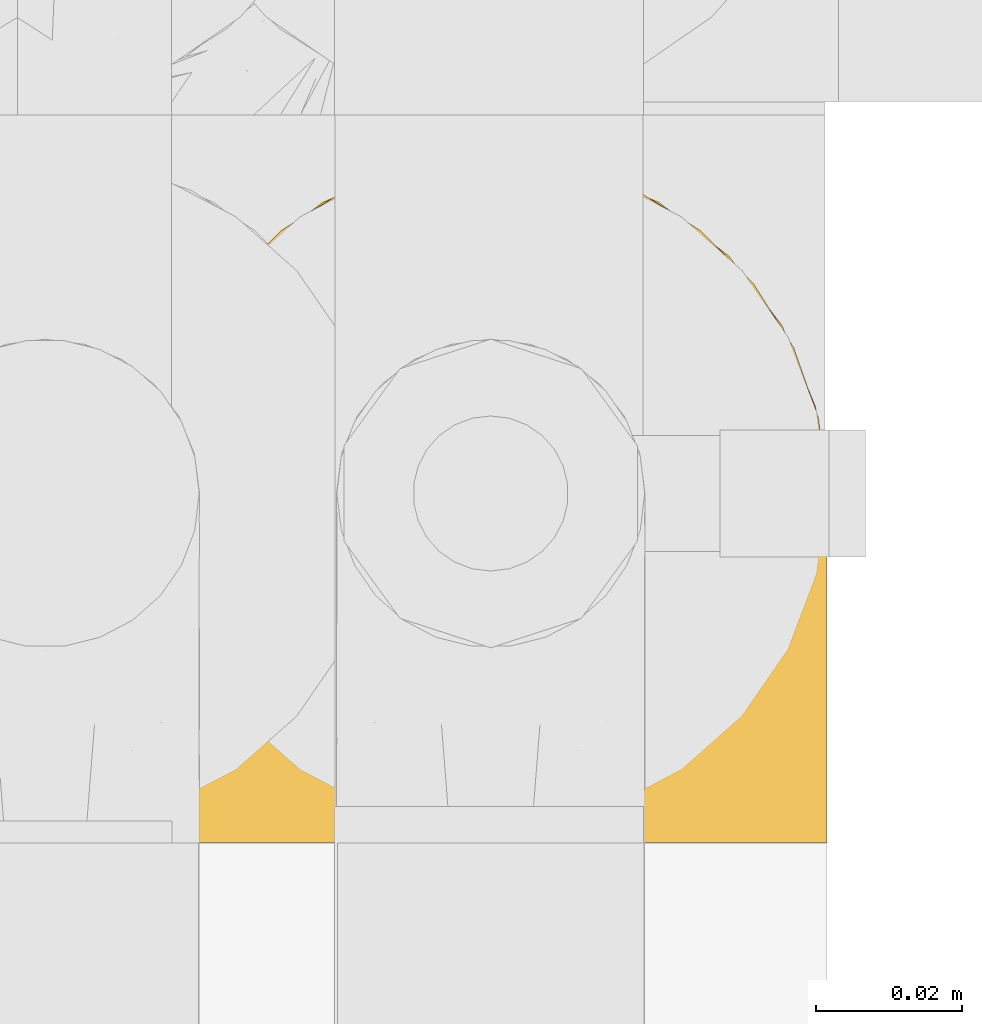
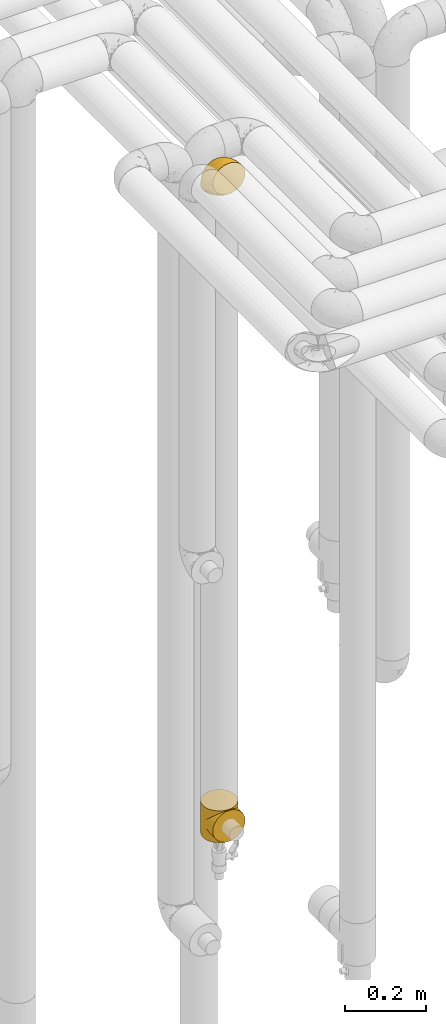
# One storey, part 237 of 827: 2 coverings.
"""IFC2X3 building model written with IfcOpenShell, lengths in millimetres."""

from ifc_helpers import new_model, entity, si_unit, converted_unit, derived_unit, direction, frame, origin, place, context, subcontext, project, spatial, faceted_brep, element, save


model = new_model("IFC2X3")

# Units and contexts
model_context = context("Model", 3, precision=0.01, world=origin(), true_north=direction((6.12303176911189e-17, 1.0)))
body_context = subcontext(model_context, "Body", "Model", "MODEL_VIEW")
ifc_project = project(units=[si_unit("LENGTHUNIT", "METRE", prefix="MILLI"), si_unit("AREAUNIT", "SQUARE_METRE"), si_unit("VOLUMEUNIT", "CUBIC_METRE"), converted_unit("PLANEANGLEUNIT", "DEGREE", entity("IfcRatioMeasure", 0.0174532925199433), si_unit("PLANEANGLEUNIT", "RADIAN"), dimensions=[0, 0, 0, 0, 0, 0, 0]), si_unit("MASSUNIT", "GRAM", prefix="KILO"), derived_unit("MASSDENSITYUNIT", [(si_unit("MASSUNIT", "GRAM", prefix="KILO"), 1), (si_unit("LENGTHUNIT", "METRE"), -3)]), derived_unit("MOMENTOFINERTIAUNIT", [(si_unit("LENGTHUNIT", "METRE"), 4)]), si_unit("TIMEUNIT", "SECOND"), si_unit("FREQUENCYUNIT", "HERTZ"), si_unit("THERMODYNAMICTEMPERATUREUNIT", "DEGREE_CELSIUS"), derived_unit("THERMALTRANSMITTANCEUNIT", [(si_unit("MASSUNIT", "GRAM", prefix="KILO"), 1), (si_unit("THERMODYNAMICTEMPERATUREUNIT", "KELVIN"), -1), (si_unit("TIMEUNIT", "SECOND"), -3)]), derived_unit("VOLUMETRICFLOWRATEUNIT", [(si_unit("LENGTHUNIT", "METRE"), 3), (si_unit("TIMEUNIT", "SECOND"), -1)]), derived_unit("MASSFLOWRATEUNIT", [(si_unit("MASSUNIT", "GRAM", prefix="KILO"), 1), (si_unit("TIMEUNIT", "SECOND"), -1)]), derived_unit("ROTATIONALFREQUENCYUNIT", [(si_unit("TIMEUNIT", "SECOND"), -1)]), si_unit("ELECTRICCURRENTUNIT", "AMPERE"), si_unit("ELECTRICVOLTAGEUNIT", "VOLT"), si_unit("POWERUNIT", "WATT"), si_unit("FORCEUNIT", "NEWTON", prefix="KILO"), si_unit("ILLUMINANCEUNIT", "LUX"), si_unit("LUMINOUSFLUXUNIT", "LUMEN"), si_unit("LUMINOUSINTENSITYUNIT", "CANDELA"), derived_unit("USERDEFINED", [(si_unit("MASSUNIT", "GRAM", prefix="KILO"), -1), (si_unit("LENGTHUNIT", "METRE"), -2), (si_unit("TIMEUNIT", "SECOND"), 3), (si_unit("LUMINOUSFLUXUNIT", "LUMEN"), 1)]), derived_unit("LINEARVELOCITYUNIT", [(si_unit("LENGTHUNIT", "METRE"), 1), (si_unit("TIMEUNIT", "SECOND"), -1)]), si_unit("PRESSUREUNIT", "PASCAL"), derived_unit("USERDEFINED", [(si_unit("LENGTHUNIT", "METRE"), -2), (si_unit("MASSUNIT", "GRAM", prefix="KILO"), 1), (si_unit("TIMEUNIT", "SECOND"), -2)]), derived_unit("LINEARFORCEUNIT", [(si_unit("MASSUNIT", "GRAM", prefix="KILO"), 1), (si_unit("LENGTHUNIT", "METRE"), 1), (si_unit("TIMEUNIT", "SECOND"), -2), (si_unit("LENGTHUNIT", "METRE"), -1)]), derived_unit("PLANARFORCEUNIT", [(si_unit("MASSUNIT", "GRAM", prefix="KILO"), 1), (si_unit("LENGTHUNIT", "METRE"), 1), (si_unit("TIMEUNIT", "SECOND"), -2), (si_unit("LENGTHUNIT", "METRE"), -2)])], contexts=[model_context])

# Site, building, storey
site_placement = place(None, origin())
site = spatial("IfcSite", under=ifc_project, at=site_placement, CompositionType="ELEMENT")
building_placement = place(site_placement, origin())
building = spatial("IfcBuilding", under=site, at=building_placement, CompositionType="ELEMENT")
storey_placement = place(building_placement, frame((0.0, 0.0, 28200.0)))
storey = spatial("IfcBuildingStorey", under=building, at=storey_placement, Name="08", CompositionType="ELEMENT", Elevation=28200.0)

# Coverings
covering_1_placement = place(storey_placement, frame((30683.75, 14866.61, 3350.4)))
element("IfcCovering", 1, at=covering_1_placement, inside=storey, Name=":ADSK_", ObjectType=":ADSK_", PredefinedType="INSULATION", context=body_context, shape_type="Brep", body=[
    faceted_brep([(11.68, 78.41, 1.6), (19.0, 85.72, 1.6), (27.76, 91.22, 1.6), (37.52, 94.64, 1.6), (47.8, 95.8, 1.6), (58.08, 94.64, 1.6), (67.85, 91.22, 1.6), (76.61, 85.71, 1.6), (83.92, 78.39, 1.6), (89.42, 69.63, 1.6), (92.84, 59.87, 1.6), (94.0, 49.6, 1.6), (93.53, 45.45, 1.6), (93.18, 42.38, 1.6), (92.84, 39.31, 1.6), (91.13, 34.43, 1.6), (89.42, 29.54, 1.6), (86.66, 25.16, 1.6), (83.91, 20.78, 1.6), (80.25, 17.13, 1.6), (76.59, 13.47, 1.6), (67.83, 7.97, 1.6), (62.95, 6.26, 1.6), (58.07, 4.55, 1.6), (47.8, 3.4, 1.6), (37.51, 4.55, 1.6), (32.63, 6.26, 1.6), (27.74, 7.97, 1.6), (18.98, 13.48, 1.6), (15.33, 17.14, 1.6), (11.67, 20.8, 1.6), (8.92, 25.18, 1.6), (6.17, 29.56, 1.6), (4.46, 34.44, 1.6), (2.75, 39.32, 1.6), (2.41, 42.39, 1.6), (2.06, 45.45, 1.6), (1.6, 49.6, 1.6), (2.75, 59.88, 1.6), (6.17, 69.65, 1.6), (47.8, 1.6, 3.4), (59.75, 1.6, 4.97), (70.9, 1.6, 9.58), (75.68, 1.6, 13.26), (80.46, 1.6, 16.93), (84.13, 1.6, 21.71), (87.81, 1.6, 26.5), (90.11, 1.6, 32.07), (92.42, 1.6, 37.64), (92.9, 1.6, 41.25), (93.17, 1.6, 43.34), (93.45, 1.6, 45.42), (94.0, 1.6, 49.6), (92.42, 1.6, 61.55), (87.81, 1.6, 72.7), (80.46, 1.6, 82.26), (70.9, 1.6, 89.61), (59.75, 1.6, 94.22), (47.8, 1.6, 95.8), (35.84, 1.6, 94.22), (24.7, 1.6, 89.61), (15.13, 1.6, 82.26), (7.78, 1.6, 72.7), (3.17, 1.6, 61.55), (1.6, 1.6, 49.6), (2.14, 1.6, 45.42), (2.69, 1.6, 41.25), (3.17, 1.6, 37.64), (5.48, 1.6, 32.07), (7.78, 1.6, 26.5), (11.46, 1.6, 21.71), (15.13, 1.6, 16.93), (19.91, 1.6, 13.26), (24.7, 1.6, 9.58), (35.84, 1.6, 4.97), (23.61, 36.81, 81.55), (31.99, 23.28, 90.4), (35.87, 45.8, 83.0), (47.8, 30.7, 91.18), (40.43, 21.2, 93.13), (47.8, 12.96, 94.0), (31.83, 66.19, 66.19), (23.37, 54.51, 70.92), (21.41, 17.98, 85.95), (3.07, 36.69, 49.74), (1.6, 35.54, 35.54), (1.6, 31.64, 38.14), (1.6, 27.75, 40.74), (1.6, 23.86, 43.34), (1.6, 19.96, 45.94), (13.45, 22.8, 77.59), (15.25, 42.67, 71.17), (8.07, 33.21, 65.81), (16.0, 59.45, 59.03), (17.34, 71.5, 45.85), (10.58, 62.66, 45.79), (5.34, 54.5, 41.42), (2.39, 47.57, 34.51), (8.36, 48.81, 56.04), (10.04, 74.98, 15.15), (2.59, 18.7, 56.51), (6.28, 15.75, 68.39), (34.28, 91.17, 23.33), (38.73, 85.28, 42.86), (27.25, 82.58, 39.42), (29.88, 75.78, 53.58), (38.6, 74.98, 59.17), (23.44, 67.27, 59.06), (25.25, 87.38, 22.63), (17.23, 82.04, 20.55), (47.8, 94.0, 12.96), (47.8, 77.8, 56.96), (47.8, 67.38, 67.38), (2.53, 56.2, 18.72), (1.6, 48.85, 5.33), (1.6, 48.11, 9.07), (1.6, 47.57, 11.79), (1.6, 47.03, 14.51), (1.6, 46.48, 17.24), (1.6, 45.94, 19.96), (5.71, 65.78, 21.03), (1.6, 17.24, 46.48), (1.6, 14.51, 47.03), (1.6, 11.79, 47.57), (1.6, 9.07, 48.11), (1.6, 7.2, 48.48), (1.6, 5.33, 48.85), (47.8, 91.18, 30.7), (1.6, 43.34, 23.86), (1.6, 40.74, 27.75), (1.6, 38.14, 31.64), (11.89, 72.73, 31.26), (47.8, 56.96, 77.8), (39.69, 62.23, 72.75), (47.8, 84.49, 43.83), (47.8, 43.83, 84.49), (13.84, 12.05, 14.58), (9.16, 18.95, 16.17), (15.79, 13.02, 10.82), (25.75, 8.34, 4.64), (16.09, 14.63, 7.71), (7.51, 11.09, 25.13), (3.99, 13.66, 32.66), (2.66, 20.08, 34.94), (3.16, 9.61, 36.76), (2.35, 9.48, 40.48), (2.23, 16.1, 39.25), (38.35, 3.42, 3.69), (6.18, 26.63, 13.99), (2.7, 33.72, 21.85), (2.93, 34.77, 17.93), (16.01, 6.75, 15.11), (9.08, 13.31, 21.14), (9.3, 21.11, 12.7), (11.68, 19.94, 7.21), (4.65, 8.67, 32.27), (3.65, 26.11, 25.68), (3.61, 29.3, 22.18), (12.8, 6.32, 18.79), (2.43, 39.92, 10.12), (6.83, 27.05, 9.47), (21.65, 6.04, 10.45), (3.7, 34.4, 11.29), (47.8, 2.87, 2.87), (3.37, 20.92, 31.16), (7.03, 27.43, 6.31), (7.87, 7.54, 25.62), (7.26, 18.45, 21.18), (3.41, 23.88, 28.81), (23.81, 7.77, 7.45), (86.5, 13.3, 21.14), (88.08, 11.09, 25.13), (82.79, 6.33, 18.79), (94.0, 9.07, 48.11), (94.0, 5.33, 48.85), (94.0, 14.51, 47.03), (94.0, 11.79, 47.57), (57.24, 3.42, 3.69), (71.76, 7.76, 7.44), (94.0, 47.03, 14.51), (94.0, 47.57, 11.79), (94.0, 48.85, 5.33), (94.0, 48.11, 9.07), (79.49, 14.62, 7.71), (88.75, 27.03, 9.47), (92.93, 20.08, 34.94), (92.22, 20.92, 31.16), (94.0, 27.75, 40.74), (94.0, 31.64, 38.14), (92.43, 9.61, 36.76), (93.24, 9.48, 40.48), (69.82, 8.33, 4.63), (79.57, 6.74, 15.11), (81.74, 12.04, 14.58), (94.0, 23.86, 43.34), (94.0, 19.96, 45.94), (93.36, 16.1, 39.25), (83.9, 19.93, 7.21), (86.28, 21.1, 12.69), (93.16, 39.92, 10.14), (92.88, 33.68, 21.81), (91.98, 29.28, 22.19), (89.41, 26.62, 14.0), (91.93, 26.08, 25.69), (86.42, 18.93, 16.17), (88.82, 27.87, 6.66), (92.66, 34.75, 17.92), (73.93, 6.04, 10.45), (94.0, 38.14, 31.64), (79.5, 12.79, 10.64), (91.89, 34.41, 11.31), (94.0, 45.94, 19.96), (94.0, 43.34, 23.86), (94.0, 40.74, 27.75), (91.6, 13.66, 32.66), (94.0, 17.24, 46.48), (90.94, 8.67, 32.27), (94.0, 35.54, 35.54), (92.16, 23.83, 28.77), (88.32, 18.43, 21.17), (86.13, 6.03, 23.36), (94.0, 46.48, 17.24), (93.2, 34.52, 47.58), (55.16, 21.2, 93.13), (82.02, 23.82, 77.44), (84.29, 41.32, 66.78), (76.94, 47.62, 71.68), (68.33, 52.66, 74.96), (71.98, 36.81, 81.55), (92.52, 49.75, 36.7), (92.9, 19.07, 56.9), (59.72, 45.8, 83.0), (63.6, 23.28, 90.4), (88.89, 21.35, 67.83), (74.18, 17.98, 85.95), (68.35, 82.57, 39.41), (61.33, 91.17, 23.33), (56.86, 85.27, 42.87), (68.62, 73.89, 53.92), (63.76, 66.19, 66.19), (72.19, 62.43, 64.12), (88.69, 63.53, 33.13), (92.19, 58.45, 23.1), (89.75, 67.16, 16.98), (59.86, 76.72, 55.72), (55.9, 62.22, 72.75), (77.99, 81.54, 23.77), (85.21, 74.8, 18.41), (74.99, 75.83, 43.7), (90.23, 41.45, 54.53), (70.75, 88.2, 17.73), (81.72, 71.6, 38.98), (86.53, 56.23, 50.28), (79.6, 59.44, 59.02)], [[[0, 1, 2, 3, 4, 5, 6, 7, 8, 9, 10, 11, 12, 13, 14, 15, 16, 17, 18, 19, 20, 21, 22, 23, 24, 25, 26, 27, 28, 29, 30, 31, 32, 33, 34, 35, 36, 37, 38, 39]], [[40, 41, 42, 43, 44, 45, 46, 47, 48, 49, 50, 51, 52, 53, 54, 55, 56, 57, 58, 59, 60, 61, 62, 63, 64, 65, 66, 67, 68, 69, 70, 71, 72, 73, 74]], [[75, 76, 77]], [[78, 79, 80]], [[77, 81, 82]], [[76, 75, 83]], [[84, 85, 86, 87, 88, 89]], [[90, 91, 92]], [[76, 60, 59]], [[93, 94, 95]], [[90, 62, 61]], [[83, 61, 60]], [[96, 97, 84]], [[98, 93, 95]], [[0, 39, 99]], [[100, 84, 89]], [[62, 101, 63]], [[2, 102, 3]], [[92, 84, 100]], [[103, 102, 104]], [[103, 105, 106]], [[93, 107, 94]], [[1, 108, 2]], [[92, 101, 90]], [[108, 1, 109]], [[102, 110, 3]], [[93, 82, 107]], [[102, 108, 104]], [[111, 106, 112]], [[109, 0, 99]], [[113, 37, 114, 115, 116, 117, 118, 119]], [[120, 38, 113]], [[100, 89, 121, 122, 123, 124, 125, 126, 64]], [[127, 102, 103]], [[97, 119, 128, 129, 130, 85]], [[99, 120, 131]], [[132, 133, 77]], [[59, 80, 79]], [[1, 0, 109]], [[98, 84, 92]], [[94, 109, 131]], [[120, 39, 38]], [[93, 91, 82]], [[104, 94, 105]], [[97, 113, 119]], [[95, 120, 96]], [[83, 90, 61]], [[91, 93, 98]], [[64, 63, 100]], [[100, 63, 101]], [[77, 76, 79]], [[133, 106, 81]], [[84, 97, 85]], [[113, 96, 120]], [[113, 97, 96]], [[37, 113, 38]], [[110, 102, 127]], [[110, 4, 3]], [[103, 111, 134, 127]], [[90, 75, 91]], [[82, 81, 107]], [[91, 75, 82]], [[77, 82, 75]], [[76, 83, 60]], [[90, 83, 75]], [[105, 107, 81]], [[94, 131, 95]], [[105, 94, 107]], [[109, 94, 104]], [[120, 95, 131]], [[98, 95, 96]], [[84, 98, 96]], [[98, 92, 91]], [[106, 105, 81]], [[103, 104, 105]], [[112, 106, 133]], [[103, 106, 111]], [[112, 133, 132]], [[81, 77, 133]], [[77, 78, 135, 132]], [[120, 99, 39]], [[109, 99, 131]], [[59, 58, 80]], [[59, 79, 76]], [[90, 101, 62]], [[100, 101, 92]], [[2, 108, 102]], [[109, 104, 108]], [[78, 77, 79]], [[136, 137, 138]], [[27, 139, 140]], [[141, 142, 143]], [[144, 145, 121]], [[146, 89, 88]], [[147, 139, 25]], [[148, 149, 150]], [[136, 151, 152]], [[147, 40, 74]], [[24, 147, 25]], [[140, 153, 154]], [[33, 116, 34]], [[73, 72, 151]], [[114, 37, 36, 35, 34, 116, 115]], [[146, 155, 144]], [[156, 85, 130]], [[157, 149, 148]], [[151, 158, 152]], [[117, 33, 159]], [[29, 154, 160]], [[161, 74, 73]], [[162, 128, 119]], [[66, 65, 64, 126, 125, 124, 123, 122, 67]], [[163, 147, 24]], [[27, 140, 28]], [[149, 129, 150]], [[139, 27, 26, 25]], [[68, 144, 69]], [[129, 128, 150]], [[164, 87, 86]], [[130, 129, 149]], [[122, 145, 67]], [[154, 153, 148]], [[162, 119, 159]], [[165, 30, 160]], [[150, 160, 148]], [[128, 162, 150]], [[30, 165, 31]], [[145, 144, 68]], [[89, 146, 144]], [[87, 164, 143]], [[166, 155, 142]], [[88, 87, 143]], [[162, 160, 150]], [[160, 30, 29]], [[154, 29, 28]], [[140, 154, 28]], [[160, 154, 148]], [[140, 137, 153]], [[157, 148, 153]], [[156, 130, 157]], [[153, 137, 157]], [[157, 137, 156]], [[167, 137, 136]], [[168, 85, 156]], [[152, 168, 167]], [[167, 168, 156]], [[164, 152, 141]], [[71, 158, 72]], [[152, 167, 136]], [[88, 142, 146]], [[144, 155, 69]], [[146, 142, 155]], [[70, 166, 71]], [[142, 141, 166]], [[70, 69, 155]], [[141, 158, 71]], [[161, 73, 151]], [[138, 137, 140]], [[161, 136, 169]], [[136, 161, 151]], [[74, 161, 169]], [[152, 158, 141]], [[151, 72, 158]], [[168, 152, 164]], [[137, 167, 156]], [[164, 86, 168]], [[85, 168, 86]], [[116, 33, 117]], [[130, 149, 157]], [[67, 145, 68]], [[121, 89, 144]], [[145, 122, 121]], [[40, 147, 163]], [[169, 147, 74]], [[159, 33, 32]], [[162, 159, 32]], [[159, 119, 118, 117]], [[139, 147, 169]], [[139, 169, 138]], [[162, 32, 31]], [[141, 143, 164]], [[88, 143, 142]], [[71, 166, 141]], [[155, 166, 70]], [[139, 138, 140]], [[169, 136, 138]], [[160, 162, 165]], [[162, 31, 165]], [[170, 171, 172]], [[173, 174, 52, 51, 50, 49, 48, 175, 176]], [[177, 178, 41]], [[179, 15, 180]], [[12, 11, 181, 182, 180, 14, 13]], [[183, 21, 20]], [[19, 18, 184]], [[185, 186, 187]], [[186, 188, 187]], [[43, 172, 44]], [[189, 190, 47]], [[23, 22, 21, 191]], [[170, 192, 193]], [[40, 163, 177]], [[194, 195, 196]], [[24, 23, 177]], [[197, 198, 183]], [[199, 15, 179]], [[47, 46, 189]], [[200, 201, 202]], [[201, 203, 204]], [[205, 206, 184]], [[207, 41, 178]], [[16, 15, 199]], [[14, 180, 15]], [[202, 201, 198]], [[208, 201, 200]], [[163, 24, 177]], [[48, 47, 190]], [[196, 195, 189]], [[197, 184, 202]], [[204, 193, 209]], [[210, 211, 212]], [[206, 212, 213]], [[205, 17, 210]], [[184, 206, 202]], [[210, 212, 206]], [[185, 194, 214]], [[189, 215, 190]], [[216, 45, 214]], [[186, 171, 170]], [[189, 216, 196]], [[197, 20, 19]], [[194, 185, 187]], [[197, 183, 20]], [[184, 197, 19]], [[197, 202, 198]], [[206, 200, 202]], [[204, 183, 198]], [[201, 208, 203]], [[203, 208, 217]], [[204, 198, 201]], [[217, 188, 218]], [[193, 219, 170]], [[171, 186, 185]], [[170, 218, 186]], [[170, 219, 218]], [[42, 207, 192]], [[171, 220, 172]], [[216, 189, 46]], [[214, 194, 196]], [[44, 220, 45]], [[214, 196, 216]], [[216, 46, 45]], [[214, 45, 220]], [[192, 43, 42]], [[204, 203, 219]], [[207, 193, 192]], [[209, 193, 178]], [[41, 207, 42]], [[193, 207, 178]], [[43, 192, 172]], [[170, 172, 192]], [[204, 219, 193]], [[219, 203, 218]], [[217, 218, 203]], [[188, 186, 218]], [[206, 213, 200]], [[208, 200, 213]], [[199, 210, 16]], [[215, 189, 195]], [[215, 175, 190]], [[175, 48, 190]], [[199, 179, 221, 211]], [[210, 199, 211]], [[23, 191, 177]], [[40, 177, 41]], [[178, 177, 191]], [[21, 183, 191]], [[209, 191, 183]], [[205, 18, 17]], [[17, 16, 210]], [[171, 185, 214]], [[172, 220, 44]], [[214, 220, 171]], [[191, 209, 178]], [[204, 209, 183]], [[206, 205, 210]], [[18, 205, 184]], [[222, 195, 194, 187, 188, 217]], [[57, 223, 80]], [[224, 225, 226]], [[226, 227, 228]], [[229, 217, 208, 213, 212, 211]], [[230, 52, 174, 173, 176, 175, 215, 195]], [[231, 232, 228]], [[231, 78, 223]], [[223, 57, 232]], [[224, 233, 225]], [[233, 54, 53]], [[234, 232, 56]], [[56, 55, 234]], [[234, 224, 228]], [[235, 236, 237]], [[224, 55, 54]], [[238, 239, 240]], [[52, 230, 53]], [[241, 242, 243]], [[239, 244, 245]], [[11, 10, 242]], [[236, 6, 5]], [[7, 246, 8]], [[8, 247, 9]], [[238, 248, 235]], [[222, 229, 249]], [[242, 211, 221, 179, 180, 182, 181, 11]], [[233, 53, 230]], [[111, 112, 244]], [[250, 6, 236]], [[247, 251, 241]], [[6, 250, 7]], [[127, 236, 110]], [[249, 229, 252]], [[247, 8, 246]], [[235, 246, 250]], [[236, 5, 110]], [[235, 244, 238]], [[237, 236, 127]], [[243, 9, 247]], [[252, 229, 241]], [[56, 232, 57]], [[222, 230, 195]], [[225, 249, 252]], [[249, 233, 230]], [[54, 233, 224]], [[231, 228, 227]], [[245, 132, 231]], [[249, 225, 233]], [[226, 225, 253]], [[235, 250, 236]], [[246, 7, 250]], [[251, 247, 246]], [[243, 247, 241]], [[248, 246, 235]], [[252, 251, 253]], [[229, 222, 217]], [[230, 222, 249]], [[5, 4, 110]], [[237, 127, 134, 111]], [[238, 244, 239]], [[224, 234, 55]], [[232, 234, 228]], [[242, 241, 229]], [[10, 9, 243]], [[211, 242, 229]], [[10, 243, 242]], [[80, 223, 78]], [[80, 58, 57]], [[231, 223, 232]], [[227, 240, 239]], [[224, 226, 228]], [[240, 226, 253]], [[227, 239, 245]], [[226, 240, 227]], [[251, 248, 253]], [[240, 253, 248]], [[244, 235, 237]], [[237, 111, 244]], [[132, 245, 112]], [[112, 245, 244]], [[135, 78, 231, 132]], [[227, 245, 231]], [[248, 238, 240]], [[246, 248, 251]], [[251, 252, 241]], [[225, 252, 253]]]),
])
covering_2_placement = place(storey_placement, frame((30683.75, 14868.2, 1404.5)))
element("IfcCovering", 2, at=covering_2_placement, inside=storey, Name=":ADSK_", ObjectType=":ADSK_", PredefinedType="INSULATION", context=body_context, shape_type="Brep", body=[
    faceted_brep([(93.48, 41.09, 54.91), (94.0, 48.0, 96.0), (92.42, 36.04, 96.0), (70.23, 7.85, 88.15), (68.11, 6.84, 96.0), (66.38, 5.7, 90.3), (87.81, 24.9, 96.0), (89.25, 27.6, 68.4), (85.44, 21.22, 74.78), (80.46, 15.33, 96.0), (70.9, 7.99, 96.0), (59.75, 3.37, 96.0), (58.58, 3.18, 92.82), (59.69, 3.54, 92.46), (61.92, 4.26, 91.74), (94.0, 48.0, 48.0), (93.48, 41.09, 41.09), (94.0, 48.0, 0.0), (57.46, 2.82, 93.18), (58.26, 3.18, 96.0), (56.76, 2.98, 96.0), (91.91, 34.26, 61.74), (51.53, 2.29, 96.0), (50.78, 2.19, 96.0), (51.42, 2.18, 93.82), (52.28, 2.39, 96.0), (74.07, 10.0, 86.0), (75.68, 11.66, 96.0), (62.54, 4.53, 96.0), (64.15, 4.98, 91.02), (65.32, 5.68, 96.0), (49.29, 2.0, 96.0), (49.0, 1.93, 94.07), (50.21, 2.06, 93.94), (52.63, 2.31, 93.69), (55.27, 2.78, 96.0), (53.77, 2.59, 96.0), (55.05, 2.57, 93.43), (80.41, 15.28, 80.72), (56.26, 2.7, 93.3), (53.84, 2.44, 93.56), (47.8, 1.8, 96.0), (47.8, 1.8, 94.2), (47.8, 1.8, 0.0), (49.0, 1.93, 1.93), (47.8, 1.8, 1.8), (50.04, 2.1, 96.0), (33.66, 4.27, 91.73), (35.84, 3.37, 96.0), (33.05, 4.53, 96.0), (43.31, 2.39, 96.0), (41.82, 2.59, 96.0), (42.95, 2.31, 93.69), (35.89, 3.55, 92.45), (37.0, 3.19, 92.81), (30.27, 5.68, 96.0), (29.21, 5.7, 90.3), (31.43, 4.98, 91.02), (38.11, 2.83, 93.17), (38.83, 2.98, 96.0), (37.33, 3.18, 96.0), (27.48, 6.84, 96.0), (24.7, 7.99, 96.0), (25.37, 7.85, 88.15), (21.52, 10.0, 86.0), (19.91, 11.66, 96.0), (15.18, 15.27, 80.73), (45.37, 2.06, 93.94), (46.3, 2.0, 96.0), (45.55, 2.1, 96.0), (44.81, 2.19, 96.0), (15.13, 15.33, 96.0), (10.15, 21.21, 74.79), (7.78, 24.9, 96.0), (40.53, 2.57, 93.43), (41.74, 2.44, 93.56), (6.34, 27.6, 68.4), (3.17, 36.04, 96.0), (39.32, 2.7, 93.3), (40.32, 2.78, 96.0), (2.11, 41.09, 54.91), (1.6, 48.0, 96.0), (3.69, 34.26, 61.74), (1.6, 48.0, 48.0), (2.11, 41.09, 41.09), (1.6, 48.0, 0.0), (46.59, 1.93, 94.07), (44.16, 2.18, 93.82), (44.06, 2.29, 96.0), (46.59, 1.93, 1.93), (24.7, 88.01, 0.0), (35.84, 92.63, 0.0), (47.8, 94.2, 0.0), (59.75, 92.63, 0.0), (70.9, 88.01, 0.0), (80.46, 80.67, 0.0), (87.81, 71.1, 0.0), (92.42, 59.96, 0.0), (92.42, 36.04, 0.0), (87.81, 24.9, 0.0), (80.46, 15.33, 0.0), (75.68, 11.66, 0.0), (70.9, 7.99, 0.0), (68.11, 6.84, 0.0), (65.32, 5.68, 0.0), (62.54, 4.53, 0.0), (59.75, 3.37, 0.0), (58.26, 3.18, 0.0), (56.76, 2.98, 0.0), (55.27, 2.78, 0.0), (53.77, 2.59, 0.0), (52.28, 2.39, 0.0), (51.53, 2.29, 0.0), (50.78, 2.19, 0.0), (50.04, 2.1, 0.0), (49.29, 2.0, 0.0), (46.3, 2.0, 0.0), (45.55, 2.1, 0.0), (44.81, 2.19, 0.0), (44.06, 2.29, 0.0), (43.31, 2.39, 0.0), (41.82, 2.59, 0.0), (40.32, 2.78, 0.0), (38.83, 2.98, 0.0), (37.33, 3.18, 0.0), (35.84, 3.37, 0.0), (33.05, 4.53, 0.0), (30.27, 5.68, 0.0), (27.48, 6.84, 0.0), (24.7, 7.99, 0.0), (19.91, 11.66, 0.0), (15.13, 15.33, 0.0), (7.78, 24.9, 0.0), (3.17, 36.04, 0.0), (3.17, 59.96, 0.0), (7.78, 71.1, 0.0), (15.13, 80.67, 0.0), (92.42, 59.96, 96.0), (87.81, 71.1, 96.0), (80.46, 80.67, 96.0), (70.9, 88.01, 96.0), (59.75, 92.63, 96.0), (47.8, 94.2, 96.0), (35.84, 92.63, 96.0), (24.7, 88.01, 96.0), (15.13, 80.67, 96.0), (7.78, 71.1, 96.0), (3.17, 59.96, 96.0), (61.92, 4.26, 4.26), (59.69, 3.54, 3.54), (58.58, 3.18, 3.18), (91.91, 34.26, 34.26), (89.25, 27.6, 27.6), (66.38, 5.7, 5.7), (56.26, 2.7, 2.7), (55.05, 2.57, 2.57), (85.44, 21.22, 21.22), (74.07, 10.0, 10.0), (70.23, 7.85, 7.85), (80.41, 15.28, 15.28), (64.15, 4.98, 4.98), (57.46, 2.82, 2.82), (50.21, 2.06, 2.06), (53.84, 2.44, 2.44), (52.63, 2.31, 2.31), (51.42, 2.18, 2.18), (29.21, 5.7, 5.7), (31.43, 4.98, 4.98), (21.52, 10.0, 10.0), (40.53, 2.57, 2.57), (15.18, 15.27, 15.27), (25.37, 7.85, 7.85), (39.32, 2.7, 2.7), (38.11, 2.83, 2.83), (44.16, 2.18, 2.18), (42.95, 2.31, 2.31), (33.66, 4.27, 4.27), (37.0, 3.19, 3.19), (35.89, 3.55, 3.55), (6.34, 27.6, 27.6), (3.69, 34.26, 34.26), (10.15, 21.21, 21.21), (41.74, 2.44, 2.44), (45.37, 2.06, 2.06), (94.0, 0.0, 48.0), (92.42, 0.0, 59.96), (87.81, 0.0, 71.1), (80.46, 0.0, 80.67), (75.68, 0.0, 84.34), (70.9, 0.0, 88.01), (68.11, 0.0, 89.16), (65.32, 0.0, 90.32), (62.54, 0.0, 91.47), (59.75, 0.0, 92.63), (58.26, 0.0, 92.82), (56.76, 0.0, 93.02), (55.27, 0.0, 93.22), (53.77, 0.0, 93.41), (52.28, 0.0, 93.61), (51.53, 0.0, 93.71), (50.78, 0.0, 93.81), (50.04, 0.0, 93.9), (49.29, 0.0, 94.0), (47.8, 0.0, 94.2), (46.3, 0.0, 94.0), (45.55, 0.0, 93.9), (44.81, 0.0, 93.81), (44.06, 0.0, 93.71), (43.31, 0.0, 93.61), (41.82, 0.0, 93.41), (40.32, 0.0, 93.22), (38.83, 0.0, 93.02), (37.33, 0.0, 92.82), (35.84, 0.0, 92.63), (33.05, 0.0, 91.47), (30.27, 0.0, 90.32), (27.48, 0.0, 89.16), (24.7, 0.0, 88.01), (19.91, 0.0, 84.34), (15.13, 0.0, 80.67), (7.78, 0.0, 71.1), (3.17, 0.0, 59.96), (1.6, 0.0, 48.0), (3.17, 0.0, 36.04), (7.78, 0.0, 24.9), (15.13, 0.0, 15.33), (19.91, 0.0, 11.66), (24.7, 0.0, 7.99), (27.48, 0.0, 6.84), (30.27, 0.0, 5.68), (33.05, 0.0, 4.53), (35.84, 0.0, 3.37), (37.33, 0.0, 3.18), (38.83, 0.0, 2.98), (40.32, 0.0, 2.78), (41.82, 0.0, 2.59), (43.31, 0.0, 2.39), (44.06, 0.0, 2.29), (44.81, 0.0, 2.19), (45.55, 0.0, 2.1), (46.3, 0.0, 2.0), (47.8, 0.0, 1.8), (49.29, 0.0, 2.0), (50.04, 0.0, 2.1), (50.78, 0.0, 2.19), (51.53, 0.0, 2.29), (52.28, 0.0, 2.39), (53.77, 0.0, 2.59), (55.27, 0.0, 2.78), (56.76, 0.0, 2.98), (58.26, 0.0, 3.18), (59.75, 0.0, 3.37), (62.54, 0.0, 4.53), (65.32, 0.0, 5.68), (68.11, 0.0, 6.84), (70.9, 0.0, 7.99), (75.68, 0.0, 11.66), (80.46, 0.0, 15.33), (87.81, 0.0, 24.9), (92.42, 0.0, 36.04)], [[[0, 1, 2]], [[3, 4, 5]], [[2, 6, 7]], [[8, 6, 9]], [[4, 3, 10]], [[8, 7, 6]], [[11, 12, 13, 14]], [[0, 15, 1]], [[15, 16, 17]], [[18, 19, 20]], [[7, 21, 2]], [[0, 2, 21]], [[19, 18, 12]], [[12, 11, 19]], [[22, 23, 24, 25]], [[26, 27, 10]], [[28, 29, 30]], [[28, 11, 14]], [[31, 32, 33]], [[29, 28, 14]], [[34, 25, 24]], [[35, 36, 37]], [[38, 9, 27]], [[38, 27, 26]], [[5, 30, 29]], [[20, 39, 18]], [[5, 4, 30]], [[26, 10, 3]], [[35, 39, 20]], [[9, 38, 8]], [[36, 34, 40, 37]], [[34, 36, 25]], [[39, 35, 37]], [[32, 41, 42]], [[43, 44, 45]], [[23, 33, 24]], [[33, 23, 46, 31]], [[41, 32, 31]], [[47, 48, 49]], [[50, 51, 52]], [[48, 47, 53, 54]], [[55, 56, 57]], [[58, 59, 60]], [[61, 62, 63]], [[49, 57, 47]], [[58, 60, 54]], [[64, 62, 65]], [[66, 64, 65]], [[61, 63, 56]], [[67, 68, 69, 70]], [[65, 71, 66]], [[62, 64, 63]], [[72, 71, 73]], [[51, 74, 75, 52]], [[76, 73, 77]], [[78, 79, 59]], [[59, 58, 78]], [[80, 77, 81]], [[79, 78, 74]], [[76, 72, 73]], [[80, 82, 77]], [[83, 80, 81]], [[84, 83, 85]], [[56, 55, 61]], [[76, 77, 82]], [[57, 49, 55]], [[48, 54, 60]], [[71, 72, 66]], [[74, 51, 79]], [[86, 41, 68]], [[87, 50, 52]], [[70, 87, 67]], [[50, 87, 70, 88]], [[41, 86, 42]], [[89, 43, 45]], [[68, 67, 86]], [[90, 91, 92, 93, 94, 95, 96, 97, 17, 98, 99, 100, 101, 102, 103, 104, 105, 106, 107, 108, 109, 110, 111, 112, 113, 114, 115, 43, 116, 117, 118, 119, 120, 121, 122, 123, 124, 125, 126, 127, 128, 129, 130, 131, 132, 133, 85, 134, 135, 136]], [[1, 137, 138, 139, 140, 141, 142, 143, 144, 145, 146, 147, 81, 77, 73, 71, 65, 62, 61, 55, 49, 48, 60, 59, 79, 51, 50, 88, 70, 69, 68, 41, 31, 46, 23, 22, 25, 36, 35, 20, 19, 11, 28, 30, 4, 10, 27, 9, 6, 2]], [[140, 139, 95, 94]], [[92, 142, 141, 93]], [[141, 140, 94, 93]], [[96, 138, 137, 97]], [[1, 15, 17, 97, 137]], [[95, 139, 138, 96]], [[106, 148, 149, 150]], [[151, 152, 98]], [[153, 104, 103]], [[148, 106, 105]], [[16, 151, 98]], [[109, 154, 155]], [[17, 16, 98]], [[99, 156, 100]], [[99, 98, 152]], [[156, 99, 152]], [[102, 157, 158]], [[106, 150, 107]], [[155, 110, 109]], [[157, 101, 159]], [[105, 160, 148]], [[161, 107, 150]], [[162, 115, 114, 113]], [[157, 102, 101]], [[153, 103, 158]], [[104, 153, 160]], [[159, 101, 100]], [[102, 158, 103]], [[108, 161, 154]], [[110, 155, 163, 164]], [[164, 111, 110]], [[161, 108, 107]], [[160, 105, 104]], [[159, 100, 156]], [[154, 109, 108]], [[44, 43, 115]], [[165, 111, 164]], [[113, 165, 162]], [[111, 165, 113, 112]], [[115, 162, 44]], [[166, 127, 167]], [[166, 128, 127]], [[129, 168, 130]], [[122, 121, 169]], [[170, 130, 168]], [[171, 168, 129]], [[123, 172, 173]], [[119, 118, 174, 120]], [[128, 171, 129]], [[174, 175, 120]], [[126, 125, 176]], [[171, 128, 166]], [[170, 131, 130]], [[125, 177, 178, 176]], [[179, 180, 133]], [[173, 124, 123]], [[177, 125, 124]], [[180, 84, 133]], [[131, 181, 132]], [[181, 131, 170]], [[179, 132, 181]], [[179, 133, 132]], [[121, 175, 182, 169]], [[167, 126, 176]], [[84, 85, 133]], [[126, 167, 127]], [[122, 172, 123]], [[124, 173, 177]], [[116, 89, 183]], [[175, 121, 120]], [[172, 122, 169]], [[118, 183, 174]], [[183, 118, 117, 116]], [[43, 89, 116]], [[83, 81, 147, 134, 85]], [[134, 147, 146, 135]], [[146, 145, 136, 135]], [[136, 145, 144, 90]], [[90, 144, 143, 91]], [[91, 143, 142, 92]], [[184, 185, 186, 187, 188, 189, 190, 191, 192, 193, 194, 195, 196, 197, 198, 199, 200, 201, 202, 203, 204, 205, 206, 207, 208, 209, 210, 211, 212, 213, 214, 215, 216, 217, 218, 219, 220, 221, 222, 223, 224, 225, 226, 227, 228, 229, 230, 231, 232, 233, 234, 235, 236, 237, 238, 239, 240, 241, 242, 243, 244, 245, 246, 247, 248, 249, 250, 251, 252, 253, 254, 255, 256, 257, 258, 259]], [[39, 196, 195]], [[198, 197, 34]], [[193, 14, 13, 12]], [[5, 191, 190]], [[14, 193, 192]], [[190, 189, 3]], [[192, 29, 14]], [[18, 194, 12]], [[26, 189, 188]], [[38, 26, 188]], [[190, 3, 5]], [[33, 202, 201, 200]], [[188, 187, 38]], [[189, 26, 3]], [[8, 187, 186]], [[29, 192, 191]], [[7, 186, 185]], [[193, 12, 194]], [[0, 185, 184]], [[191, 5, 29]], [[7, 8, 186]], [[197, 37, 40, 34]], [[0, 21, 185]], [[15, 0, 184]], [[18, 195, 194]], [[7, 185, 21]], [[196, 39, 37]], [[187, 8, 38]], [[37, 197, 196]], [[195, 18, 39]], [[32, 203, 202]], [[24, 198, 34]], [[200, 24, 33]], [[198, 24, 200, 199]], [[203, 32, 42]], [[202, 33, 32]], [[16, 184, 259]], [[158, 254, 153]], [[259, 258, 152]], [[156, 258, 257]], [[254, 158, 255]], [[156, 152, 258]], [[251, 150, 149, 148]], [[16, 15, 184]], [[161, 250, 249]], [[152, 151, 259]], [[16, 259, 151]], [[250, 161, 150]], [[150, 251, 250]], [[245, 244, 165, 246]], [[157, 256, 255]], [[252, 160, 253]], [[252, 251, 148]], [[242, 44, 162]], [[160, 252, 148]], [[164, 246, 165]], [[248, 247, 155]], [[159, 257, 256]], [[159, 256, 157]], [[153, 253, 160]], [[249, 154, 161]], [[153, 254, 253]], [[157, 255, 158]], [[248, 154, 249]], [[257, 159, 156]], [[247, 164, 163, 155]], [[164, 247, 246]], [[154, 248, 155]], [[44, 241, 45]], [[244, 162, 165]], [[162, 244, 243, 242]], [[241, 44, 242]], [[176, 231, 230]], [[236, 235, 175]], [[231, 176, 178, 177]], [[229, 166, 167]], [[173, 233, 232]], [[228, 227, 171]], [[230, 167, 176]], [[173, 232, 177]], [[168, 227, 226]], [[170, 168, 226]], [[228, 171, 166]], [[183, 240, 239, 238]], [[226, 225, 170]], [[227, 168, 171]], [[181, 225, 224]], [[235, 169, 182, 175]], [[179, 224, 223]], [[172, 234, 233]], [[233, 173, 172]], [[84, 223, 222]], [[234, 172, 169]], [[179, 181, 224]], [[84, 180, 223]], [[83, 84, 222]], [[166, 229, 228]], [[179, 223, 180]], [[167, 230, 229]], [[231, 177, 232]], [[225, 181, 170]], [[169, 235, 234]], [[89, 241, 240]], [[174, 236, 175]], [[238, 174, 183]], [[236, 174, 238, 237]], [[241, 89, 45]], [[240, 183, 89]], [[80, 222, 221]], [[209, 52, 75, 74]], [[221, 220, 76]], [[72, 220, 219]], [[210, 78, 211]], [[72, 76, 220]], [[63, 216, 56]], [[80, 83, 222]], [[54, 213, 212]], [[76, 82, 221]], [[80, 221, 82]], [[58, 212, 211]], [[216, 63, 217]], [[207, 206, 87, 208]], [[64, 218, 217]], [[204, 86, 67]], [[214, 213, 47]], [[57, 214, 47]], [[212, 58, 54]], [[52, 208, 87]], [[210, 209, 74]], [[66, 219, 218]], [[66, 218, 64]], [[56, 215, 57]], [[211, 78, 58]], [[56, 216, 215]], [[64, 217, 63]], [[213, 54, 53, 47]], [[219, 66, 72]], [[214, 57, 215]], [[52, 209, 208]], [[78, 210, 74]], [[86, 203, 42]], [[206, 67, 87]], [[67, 206, 205, 204]], [[203, 86, 204]]]),
])

save(model, "model.ifc")
